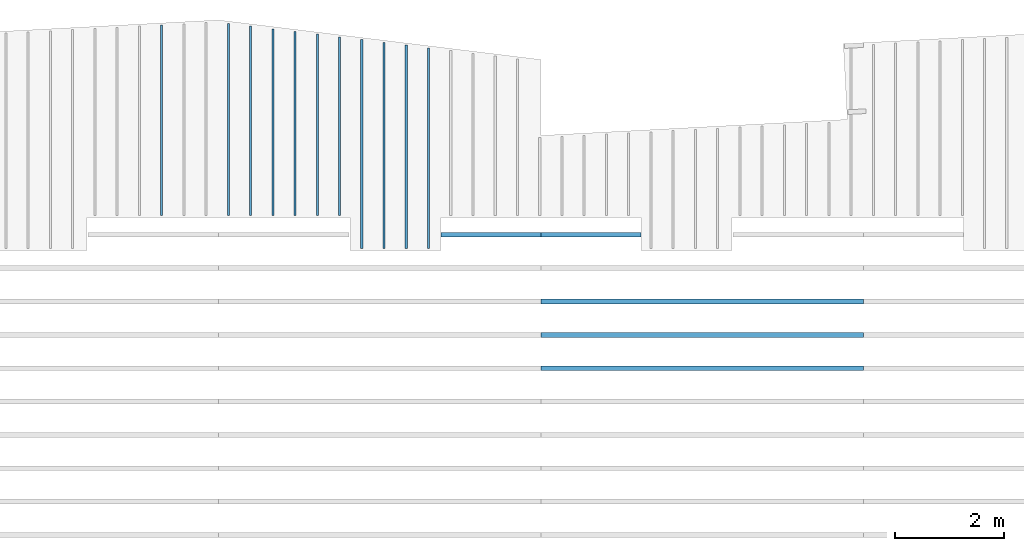
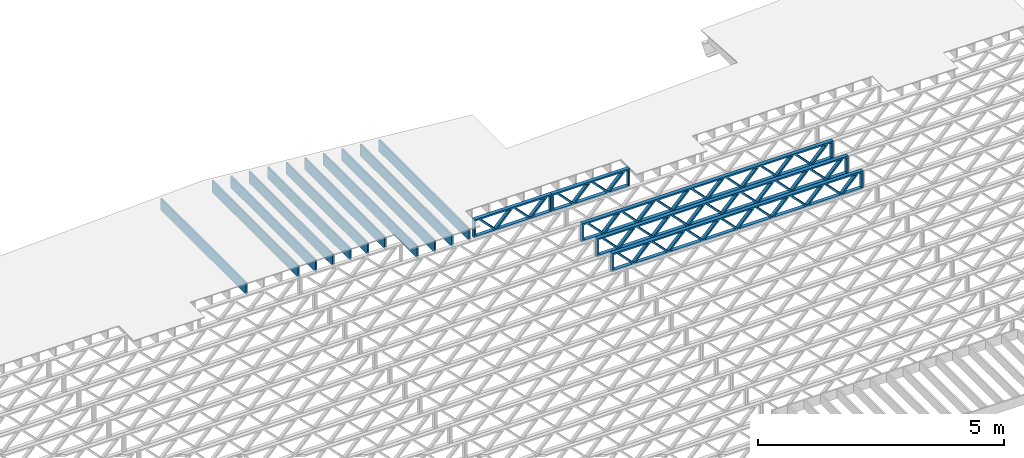
# One storey, part 9 of 13: 16 beams, 3 elements without a shape of their own.
"""IFC4 building model written with IfcOpenShell, lengths in feet."""

from ifc_helpers import new_model, entity, si_unit, converted_unit, derived_unit, direction, frame, frame_2d, origin, origin_2d_with_axis, place, context, subcontext, project, spatial, rectangle, extrude, source, transform, mapped, material, material_profile, profile_set, profile_usage, type_object, type_shapes, element, aggregate, save


model = new_model("IFC4")

# Units and contexts
model_context_1 = context("Model", 3, precision=0.0001, world=origin(), true_north=direction((6.12303176911189e-17, 1.0)))
model_context_2 = context("Model", 3, precision=0.0001, world=origin(), true_north=direction((6.12303176911189e-17, 1.0)))
body_context = subcontext(model_context_2, "Body", "Model", "MODEL_VIEW")
ifc_project = project(units=[converted_unit("LENGTHUNIT", "FOOT", entity("IfcRatioMeasure", 0.3048), si_unit("LENGTHUNIT", "METRE"), dimensions=[1, 0, 0, 0, 0, 0, 0]), converted_unit("AREAUNIT", "SQUARE FOOT", entity("IfcRatioMeasure", 0.09290304), si_unit("AREAUNIT", "SQUARE_METRE"), dimensions=[2, 0, 0, 0, 0, 0, 0]), converted_unit("VOLUMEUNIT", "CUBIC FOOT", entity("IfcRatioMeasure", 0.028316846592), si_unit("VOLUMEUNIT", "CUBIC_METRE"), dimensions=[3, 0, 0, 0, 0, 0, 0]), converted_unit("PLANEANGLEUNIT", "DEGREE", entity("IfcRatioMeasure", 0.0174532925199433), si_unit("PLANEANGLEUNIT", "RADIAN"), dimensions=[0, 0, 0, 0, 0, 0, 0]), si_unit("MASSUNIT", "GRAM", prefix="KILO"), derived_unit("MASSDENSITYUNIT", [(si_unit("MASSUNIT", "GRAM", prefix="KILO"), 1), (si_unit("LENGTHUNIT", "METRE"), -3)]), derived_unit("MOMENTOFINERTIAUNIT", [(si_unit("LENGTHUNIT", "METRE"), 4)]), si_unit("TIMEUNIT", "SECOND"), si_unit("FREQUENCYUNIT", "HERTZ"), si_unit("THERMODYNAMICTEMPERATUREUNIT", "DEGREE_CELSIUS"), derived_unit("THERMALTRANSMITTANCEUNIT", [(si_unit("MASSUNIT", "GRAM", prefix="KILO"), 1), (si_unit("THERMODYNAMICTEMPERATUREUNIT", "KELVIN"), -1), (si_unit("TIMEUNIT", "SECOND"), -3)]), derived_unit("VOLUMETRICFLOWRATEUNIT", [(si_unit("LENGTHUNIT", "METRE"), 3), (si_unit("TIMEUNIT", "SECOND"), -1)]), si_unit("ELECTRICCURRENTUNIT", "AMPERE"), si_unit("ELECTRICVOLTAGEUNIT", "VOLT"), si_unit("POWERUNIT", "WATT"), si_unit("FORCEUNIT", "NEWTON"), si_unit("ILLUMINANCEUNIT", "LUX"), si_unit("LUMINOUSFLUXUNIT", "LUMEN"), si_unit("LUMINOUSINTENSITYUNIT", "CANDELA"), derived_unit("USERDEFINED", [(si_unit("MASSUNIT", "GRAM", prefix="KILO"), -1), (si_unit("LENGTHUNIT", "METRE"), -2), (si_unit("TIMEUNIT", "SECOND"), 3), (si_unit("LUMINOUSFLUXUNIT", "LUMEN"), 1)]), derived_unit("LINEARVELOCITYUNIT", [(si_unit("LENGTHUNIT", "METRE"), 1), (si_unit("TIMEUNIT", "SECOND"), -1)]), si_unit("PRESSUREUNIT", "PASCAL"), derived_unit("USERDEFINED", [(si_unit("LENGTHUNIT", "METRE"), -2), (si_unit("MASSUNIT", "GRAM", prefix="KILO"), 1), (si_unit("TIMEUNIT", "SECOND"), -2)]), derived_unit("LINEARFORCEUNIT", [(si_unit("MASSUNIT", "GRAM", prefix="KILO"), 1), (si_unit("LENGTHUNIT", "METRE"), 1), (si_unit("TIMEUNIT", "SECOND"), -2), (si_unit("LENGTHUNIT", "METRE"), -1)]), derived_unit("PLANARFORCEUNIT", [(si_unit("MASSUNIT", "GRAM", prefix="KILO"), 1), (si_unit("LENGTHUNIT", "METRE"), 1), (si_unit("TIMEUNIT", "SECOND"), -2), (si_unit("LENGTHUNIT", "METRE"), -2)])], contexts=[model_context_1])

# Site, building, storey
site_placement = place(None, origin())
site = spatial("IfcSite", under=ifc_project, at=site_placement, CompositionType="ELEMENT")
building_placement = place(site_placement, origin())
building = spatial("IfcBuilding", under=site, at=building_placement, CompositionType="ELEMENT")
storey_placement = place(building_placement, frame((0.0, 0.0, 21.46875)))
storey = spatial("IfcBuildingStorey", under=building, at=storey_placement, Name="3RD FLOOR", CompositionType="ELEMENT", Elevation=21.46875)

# Assembly, beam
assembly_1_placement = place(storey_placement, origin())
assembly_1 = element("IfcElementAssembly", 1, at=assembly_1_placement, inside=storey, Name="Structural Beam System:Structural Framing System", ObjectType="Structural Beam System:Structural Framing System", AssemblyPlace="NOTDEFINED", PredefinedType="BEAM_GRID")
ifc_material_1 = material(Name="WOOD TRUSS", Category="Materials")
ifc_material_profile_1 = material_profile(ifc_material_1, rectangle(XDim=1.73473973950632, YDim=0.125, at=frame_2d((-1.11022302462516e-16, 8.32667268468867e-17), x_axis=(1.0, 0.0))))
ifc_material_profile_2 = material_profile(ifc_material_1, rectangle(XDim=1.73473973950633, YDim=0.125, at=frame_2d((-1.11022302462516e-16, 8.32667268468867e-17), x_axis=(1.0, 0.0))))
ifc_material_profile_3 = material_profile(ifc_material_1, rectangle(XDim=1.73473973950632, YDim=0.125, at=frame_2d((-5.55111512312578e-17, 1.38777878078145e-16), x_axis=(1.0, 0.0))))
ifc_material_profile_4 = material_profile(ifc_material_1, rectangle(XDim=1.73473973950633, YDim=0.125, at=frame_2d((-1.11022302462516e-16, 8.32667268468867e-17), x_axis=(1.0, 0.0))))
ifc_material_profile_5 = material_profile(ifc_material_1, rectangle(XDim=1.73473973950632, YDim=0.125, at=frame_2d((-1.11022302462516e-16, 8.32667268468867e-17), x_axis=(1.0, 0.0))))
ifc_material_profile_6 = material_profile(ifc_material_1, rectangle(XDim=1.73473973950633, YDim=0.125, at=frame_2d((-2.77555756156289e-16, 3.05311331771918e-16), x_axis=(1.0, 0.0))))
ifc_material_profile_7 = material_profile(ifc_material_1, rectangle(XDim=1.73473973950632, YDim=0.124999999999999, at=frame_2d((-3.88578058618805e-16, -2.4980018054066e-16), x_axis=(1.0, 0.0))))
ifc_material_profile_8 = material_profile(ifc_material_1, rectangle(XDim=1.73473973950633, YDim=0.125, at=frame_2d((2.77555756156289e-16, -3.05311331771918e-16), x_axis=(1.0, 0.0))))
ifc_material_profile_9 = material_profile(ifc_material_1, rectangle(XDim=1.73473973950632, YDim=0.124999999999999, at=frame_2d((-1.11022302462516e-16, 8.32667268468867e-17), x_axis=(1.0, 0.0))))
ifc_material_profile_10 = material_profile(ifc_material_1, rectangle(XDim=1.73473973950633, YDim=0.125, at=origin_2d_with_axis()))
ifc_material_profile_11 = material_profile(ifc_material_1, rectangle(XDim=0.124999999999982, YDim=0.291666666666668, at=origin_2d_with_axis()))
ifc_material_profile_12 = material_profile(ifc_material_1, rectangle(XDim=0.124999999999932, YDim=0.291666666666664, at=origin_2d_with_axis()))
ifc_material_profile_13 = material_profile(ifc_material_1, rectangle(XDim=1.25000000000002, YDim=0.29166666666667, at=origin_2d_with_axis()))
ifc_material_profile_14 = material_profile(ifc_material_1, rectangle(XDim=1.25000000000004, YDim=0.291666666666667, at=origin_2d_with_axis()))
ifc_profile_set_1 = profile_set([ifc_material_profile_1, ifc_material_profile_2, ifc_material_profile_3, ifc_material_profile_4, ifc_material_profile_5, ifc_material_profile_6, ifc_material_profile_7, ifc_material_profile_8, ifc_material_profile_9, ifc_material_profile_10, ifc_material_profile_11, ifc_material_profile_12, ifc_material_profile_13, ifc_material_profile_14])
ifc_profile_usage_1 = profile_usage(ifc_profile_set_1, cardinal=8)
beam_type_1 = type_object("IfcBeamType", PredefinedType="BEAM", material=ifc_profile_set_1)
shared_shape_1 = source(origin(), body_context, "Body", "SweptSolid", [
    extrude(rectangle(XDim=1.73473973950632, YDim=0.125, at=frame_2d((0.0, 1.66533453693773e-16), x_axis=(1.0, 0.0))), frame((1.95847610985504, -0.145833333333334, 0.0), z_axis=(0.0, 1.0, 0.0), x_axis=(0.693383046997606, 0.0, 0.720569184836762)), (0.0, 0.0, 1.0), 0.291666666666667),
    extrude(rectangle(XDim=1.73473973950633, YDim=0.125, at=frame_2d((-5.55111512312578e-17, 8.32667268468867e-17), x_axis=(1.0, 0.0))), frame((0.708190236181772, -0.145833333333334, 0.0), z_axis=(0.0, 1.0, 0.0), x_axis=(0.69338304699761, 0.0, -0.720569184836758)), (0.0, 0.0, 1.0), 0.291666666666667),
    extrude(rectangle(XDim=1.73473973950632, YDim=0.125, at=frame_2d((0.0, 1.66533453693773e-16), x_axis=(1.0, 0.0))), frame((-0.708190236181118, -0.145833333333334, 0.0), z_axis=(0.0, 1.0, 0.0), x_axis=(0.693383046997606, 0.0, 0.720569184836762)), (0.0, 0.0, 1.0), 0.291666666666667),
    extrude(rectangle(XDim=1.73473973950633, YDim=0.125, at=frame_2d((-2.22044604925031e-16, 2.22044604925031e-16), x_axis=(1.0, 0.0))), frame((-1.95847610985439, -0.145833333333334, 0.0), z_axis=(0.0, 1.0, 0.0), x_axis=(0.69338304699761, 0.0, -0.720569184836758)), (0.0, 0.0, 1.0), 0.291666666666666),
    extrude(rectangle(XDim=0.124999999999982, YDim=0.291666666666668, at=origin_2d_with_axis()), frame((-2.99999983968466, 0.0, 0.687500000000054), z_axis=(1.0, 0.0, 0.0), x_axis=(0.0, 0.0, -1.0)), (0.0, 0.0, 1.0), 5.99999967936932),
    extrude(rectangle(XDim=0.124999999999932, YDim=0.291666666666664, at=origin_2d_with_axis()), frame((-2.99999983968445, 0.0, -0.687499999999984), z_axis=(1.0, 0.0, 0.0), x_axis=(0.0, 0.0, -1.0)), (0.0, 0.0, 1.0), 5.99999967936911),
    extrude(rectangle(XDim=1.25000000000002, YDim=0.29166666666667, at=origin_2d_with_axis()), frame((2.87499983968464, 0.0, 0.0), z_axis=(1.0, 0.0, 0.0), x_axis=(0.0, 0.0, -1.0)), (0.0, 0.0, 1.0), 0.12500000000002),
    extrude(rectangle(XDim=1.25000000000004, YDim=0.291666666666667, at=origin_2d_with_axis()), frame((-2.99999983968466, 0.0, 0.0), z_axis=(1.0, 0.0, 0.0), x_axis=(0.0, 0.0, -1.0)), (0.0, 0.0, 1.0), 0.125000000000023),
])
type_shapes(beam_type_1, [shared_shape_1])
beam_1_placement = place(assembly_1_placement, frame((-186.738160325248, 957.861934882651, -0.947916666666874)))
beam_1 = element("IfcBeam", 2, at=beam_1_placement, type_object=beam_type_1, material=ifc_profile_usage_1, PredefinedType="BEAM", context=body_context, shape_type="MappedRepresentation", body=[
    mapped(shared_shape_1, transform((0.0, 0.0, 0.0), scale=1.0)),
])
aggregate(assembly_1, [beam_1])

# Assembly, beams
assembly_2_placement = place(storey_placement, origin())
assembly_2 = element("IfcElementAssembly", 3, at=assembly_2_placement, inside=storey, Name="Structural Beam System:Structural Framing System", ObjectType="Structural Beam System:Structural Framing System", AssemblyPlace="NOTDEFINED", PredefinedType="BEAM_GRID")
ifc_profile_usage_2 = profile_usage(ifc_profile_set_1, cardinal=8)
beam_type_2 = type_object("IfcBeamType", PredefinedType="BEAM", material=ifc_profile_set_1)
shared_shape_2 = source(origin(), body_context, "Body", "SweptSolid", [
    extrude(rectangle(XDim=1.73473973950632, YDim=0.124999999999999, at=frame_2d((5.55111512312578e-16, 7.21644966006352e-16), x_axis=(1.0, 0.0))), frame((5.95847627016997, -0.145833333333334, 0.0), z_axis=(0.0, 1.0, 0.0), x_axis=(0.693383046997606, 0.0, 0.720569184836762)), (0.0, 0.0, 1.0), 0.291666666666667),
    extrude(rectangle(XDim=1.73473973950633, YDim=0.125, at=origin_2d_with_axis()), frame((4.7081903964967, -0.145833333333334, 0.0), z_axis=(0.0, 1.0, 0.0), x_axis=(0.69338304699761, 0.0, -0.720569184836758)), (0.0, 0.0, 1.0), 0.291666666666666),
    extrude(rectangle(XDim=1.73473973950632, YDim=0.125, at=frame_2d((2.22044604925031e-16, 3.88578058618805e-16), x_axis=(1.0, 0.0))), frame((3.29180960350347, -0.145833333333334, 0.0), z_axis=(0.0, 1.0, 0.0), x_axis=(0.693383046997606, 0.0, 0.720569184836762)), (0.0, 0.0, 1.0), 0.291666666666667),
    extrude(rectangle(XDim=1.73473973950633, YDim=0.125, at=frame_2d((1.11022302462516e-16, -8.32667268468867e-17), x_axis=(1.0, 0.0))), frame((2.0415237298302, -0.145833333333334, 0.0), z_axis=(0.0, 1.0, 0.0), x_axis=(0.69338304699761, 0.0, -0.720569184836758)), (0.0, 0.0, 1.0), 0.291666666666667),
    extrude(rectangle(XDim=1.73473973950632, YDim=0.125, at=frame_2d((-5.55111512312578e-17, 1.38777878078145e-16), x_axis=(1.0, 0.0))), frame((0.625142936836964, -0.145833333333334, 0.0), z_axis=(0.0, 1.0, 0.0), x_axis=(0.693383046997606, 0.0, 0.720569184836762)), (0.0, 0.0, 1.0), 0.291666666666667),
    extrude(rectangle(XDim=1.73473973950633, YDim=0.125, at=frame_2d((-1.11022302462516e-16, 8.32667268468867e-17), x_axis=(1.0, 0.0))), frame((-0.625142936836306, -0.145833333333334, 0.0), z_axis=(0.0, 1.0, 0.0), x_axis=(0.69338304699761, 0.0, -0.720569184836758)), (0.0, 0.0, 1.0), 0.291666666666667),
    extrude(rectangle(XDim=1.73473973950632, YDim=0.125, at=frame_2d((-1.11022302462516e-16, 8.32667268468867e-17), x_axis=(1.0, 0.0))), frame((-2.04152372982954, -0.145833333333334, 0.0), z_axis=(0.0, 1.0, 0.0), x_axis=(0.693383046997606, 0.0, 0.720569184836762)), (0.0, 0.0, 1.0), 0.291666666666667),
    extrude(rectangle(XDim=1.73473973950633, YDim=0.125, at=origin_2d_with_axis()), frame((-3.29180960350281, -0.145833333333334, 0.0), z_axis=(0.0, 1.0, 0.0), x_axis=(0.69338304699761, 0.0, -0.720569184836758)), (0.0, 0.0, 1.0), 0.291666666666667),
    extrude(rectangle(XDim=1.73473973950632, YDim=0.124999999999999, at=frame_2d((-1.11022302462516e-16, 8.32667268468867e-17), x_axis=(1.0, 0.0))), frame((-4.70819039649604, -0.145833333333334, 0.0), z_axis=(0.0, 1.0, 0.0), x_axis=(0.693383046997606, 0.0, 0.720569184836762)), (0.0, 0.0, 1.0), 0.291666666666667),
    extrude(rectangle(XDim=1.73473973950633, YDim=0.125, at=frame_2d((-5.55111512312578e-16, 6.38378239159465e-16), x_axis=(1.0, 0.0))), frame((-5.95847627016931, -0.145833333333334, 0.0), z_axis=(0.0, 1.0, 0.0), x_axis=(0.69338304699761, 0.0, -0.720569184836758)), (0.0, 0.0, 1.0), 0.291666666666666),
    extrude(rectangle(XDim=1.73473973950632, YDim=0.125, at=frame_2d((-7.21644966006352e-16, -5.82867087928207e-16), x_axis=(1.0, 0.0))), frame((8.62514293683647, -0.145833333333334, 0.0), z_axis=(0.0, 1.0, 0.0), x_axis=(0.693383046997607, 0.0, 0.720569184836761)), (0.0, 0.0, 1.0), 0.291666666666667),
    extrude(rectangle(XDim=1.73473973950633, YDim=0.125, at=origin_2d_with_axis()), frame((7.3748570631632, -0.145833333333334, 0.0), z_axis=(0.0, 1.0, 0.0), x_axis=(0.69338304699761, 0.0, -0.720569184836758)), (0.0, 0.0, 1.0), 0.291666666666666),
    extrude(rectangle(XDim=1.73473973950632, YDim=0.124999999999999, at=frame_2d((-1.11022302462516e-16, 8.32667268468867e-17), x_axis=(1.0, 0.0))), frame((-7.37485706316255, -0.145833333333334, 0.0), z_axis=(0.0, 1.0, 0.0), x_axis=(0.693383046997606, 0.0, 0.720569184836762)), (0.0, 0.0, 1.0), 0.291666666666667),
    extrude(rectangle(XDim=1.73473973950633, YDim=0.125, at=origin_2d_with_axis()), frame((-8.62514293683582, -0.145833333333334, 0.0), z_axis=(0.0, 1.0, 0.0), x_axis=(0.69338304699761, 0.0, -0.720569184836758)), (0.0, 0.0, 1.0), 0.291666666666666),
    extrude(rectangle(XDim=0.124999999999982, YDim=0.291666666666668, at=origin_2d_with_axis()), frame((-9.66666666666609, 0.0, 0.687500000000054), z_axis=(1.0, 0.0, 0.0), x_axis=(0.0, 0.0, -1.0)), (0.0, 0.0, 1.0), 19.3333333333322),
    extrude(rectangle(XDim=0.124999999999932, YDim=0.291666666666664, at=origin_2d_with_axis()), frame((-9.66666666666588, 0.0, -0.687499999999984), z_axis=(1.0, 0.0, 0.0), x_axis=(0.0, 0.0, -1.0)), (0.0, 0.0, 1.0), 19.333333333332),
    extrude(rectangle(XDim=1.25000000000002, YDim=0.29166666666667, at=origin_2d_with_axis()), frame((9.54166666666607, 0.0, 0.0), z_axis=(1.0, 0.0, 0.0), x_axis=(0.0, 0.0, -1.0)), (0.0, 0.0, 1.0), 0.12500000000002),
    extrude(rectangle(XDim=1.25000000000004, YDim=0.291666666666667, at=origin_2d_with_axis()), frame((-9.66666666666609, 0.0, 0.0), z_axis=(1.0, 0.0, 0.0), x_axis=(0.0, 0.0, -1.0)), (0.0, 0.0, 1.0), 0.125000000000023),
])
type_shapes(beam_type_2, [shared_shape_2])
beam_2_placement = place(assembly_2_placement, frame((-174.071493818896, 953.861934882651, -0.947916666666661), z_axis=(0.0, 0.0, 1.0), x_axis=(-1.0, 0.0, 0.0)))
beam_2 = element("IfcBeam", 4, at=beam_2_placement, type_object=beam_type_2, material=ifc_profile_usage_2, PredefinedType="BEAM", context=body_context, shape_type="MappedRepresentation", body=[
    mapped(shared_shape_2, transform((0.0, 0.0, 0.0), scale=1.0)),
])
ifc_profile_usage_3 = profile_usage(ifc_profile_set_1, cardinal=8)
beam_3_placement = place(assembly_2_placement, frame((-174.071493818896, 951.861934882651, -0.947916666666661), z_axis=(0.0, 0.0, 1.0), x_axis=(-1.0, 0.0, 0.0)))
beam_3 = element("IfcBeam", 5, at=beam_3_placement, type_object=beam_type_2, material=ifc_profile_usage_3, PredefinedType="BEAM", context=body_context, shape_type="MappedRepresentation", body=[
    mapped(shared_shape_2, transform((0.0, 0.0, 0.0), scale=1.0)),
])
ifc_profile_usage_4 = profile_usage(ifc_profile_set_1, cardinal=8)
beam_4_placement = place(assembly_2_placement, frame((-174.071493818896, 949.861934882651, -0.947916666666661), z_axis=(0.0, 0.0, 1.0), x_axis=(-1.0, 0.0, 0.0)))
beam_4 = element("IfcBeam", 6, at=beam_4_placement, type_object=beam_type_2, material=ifc_profile_usage_4, PredefinedType="BEAM", context=body_context, shape_type="MappedRepresentation", body=[
    mapped(shared_shape_2, transform((0.0, 0.0, 0.0), scale=1.0)),
])

assembly_3_placement = place(storey_placement, origin())
assembly_3 = element("IfcElementAssembly", 7, at=assembly_3_placement, inside=storey, Name="Structural Beam System:Structural Framing System", ObjectType="Structural Beam System:Structural Framing System", AssemblyPlace="NOTDEFINED", PredefinedType="BEAM_GRID")
ifc_material_2 = material(Category="Materials")
ifc_material_profile_15 = material_profile(ifc_material_2, rectangle(XDim=0.9375, YDim=0.125000000000011, at=origin_2d_with_axis()))
ifc_profile_set_2 = profile_set([ifc_material_profile_15])
ifc_profile_usage_5 = profile_usage(ifc_profile_set_2, cardinal=8)
beam_type_3 = type_object("IfcBeamType", PredefinedType="BEAM", material=ifc_profile_set_2)
shared_shape_3 = source(origin(), body_context, "Body", "SweptSolid", [
    extrude(rectangle(XDim=0.9375, YDim=0.125000000000011, at=origin_2d_with_axis()), frame((-6.01743624187907, 0.0, 0.0), z_axis=(1.0, 0.0, 0.0), x_axis=(0.0, 0.0, -1.0)), (0.0, 0.0, 1.0), 12.0348724837581),
])
type_shapes(beam_type_3, [shared_shape_3])
beam_5_placement = place(assembly_3_placement, frame((-190.477622729298, 963.046034462908, -0.729166666666714), z_axis=(0.0, 0.0, 1.0), x_axis=(0.0, 1.0, 0.0)))
beam_5 = element("IfcBeam", 8, at=beam_5_placement, type_object=beam_type_3, material=ifc_profile_usage_5, PredefinedType="BEAM", context=body_context, shape_type="MappedRepresentation", body=[
    mapped(shared_shape_3, transform((0.0, 0.0, 0.0), scale=1.0)),
])
ifc_profile_usage_6 = profile_usage(ifc_profile_set_2, cardinal=8)
beam_type_4 = type_object("IfcBeamType", PredefinedType="BEAM", material=ifc_profile_set_2)
shared_shape_4 = source(origin(), body_context, "Body", "SweptSolid", [
    extrude(rectangle(XDim=0.9375, YDim=0.125000000000011, at=origin_2d_with_axis()), frame((-6.09929261581436, 0.0, 0.0), z_axis=(1.0, 0.0, 0.0), x_axis=(0.0, 0.0, -1.0)), (0.0, 0.0, 1.0), 12.1985852316287),
])
type_shapes(beam_type_4, [shared_shape_4])
beam_6_placement = place(assembly_3_placement, frame((-191.810956062631, 963.127890836844, -0.729166666666714), z_axis=(0.0, 0.0, 1.0), x_axis=(0.0, 1.0, 0.0)))
beam_6 = element("IfcBeam", 9, at=beam_6_placement, type_object=beam_type_4, material=ifc_profile_usage_6, PredefinedType="BEAM", context=body_context, shape_type="MappedRepresentation", body=[
    mapped(shared_shape_4, transform((0.0, 0.0, 0.0), scale=1.0)),
])
ifc_profile_usage_7 = profile_usage(ifc_profile_set_2, cardinal=8)
beam_type_5 = type_object("IfcBeamType", PredefinedType="BEAM", material=ifc_profile_set_2)
shared_shape_5 = source(origin(), body_context, "Body", "SweptSolid", [
    extrude(rectangle(XDim=0.9375, YDim=0.125000000000011, at=origin_2d_with_axis()), frame((-5.34486018441879, 0.0, 0.0), z_axis=(1.0, 0.0, 0.0), x_axis=(0.0, 0.0, -1.0)), (0.0, 0.0, 1.0), 10.6897203688376),
])
type_shapes(beam_type_5, [shared_shape_5])
beam_7_placement = place(assembly_3_placement, frame((-195.810956062631, 964.373461511808, -0.729166666666714), z_axis=(0.0, 0.0, 1.0), x_axis=(0.0, 1.0, 0.0)))
beam_7 = element("IfcBeam", 10, at=beam_7_placement, type_object=beam_type_5, material=ifc_profile_usage_7, PredefinedType="BEAM", context=body_context, shape_type="MappedRepresentation", body=[
    mapped(shared_shape_5, transform((0.0, 0.0, 0.0), scale=1.0)),
])
ifc_profile_usage_8 = profile_usage(ifc_profile_set_2, cardinal=8)
beam_type_6 = type_object("IfcBeamType", PredefinedType="BEAM", material=ifc_profile_set_2)
shared_shape_6 = source(origin(), body_context, "Body", "SweptSolid", [
    extrude(rectangle(XDim=0.9375, YDim=0.125000000000011, at=origin_2d_with_axis()), frame((-5.67228635016443, 0.0, 0.0), z_axis=(1.0, 0.0, 0.0), x_axis=(0.0, 0.0, -1.0)), (0.0, 0.0, 1.0), 11.3445727003289),
])
type_shapes(beam_type_6, [shared_shape_6])
beam_8_placement = place(assembly_3_placement, frame((-201.144289395965, 964.700886337237, -0.729166666666714), z_axis=(0.0, 0.0, 1.0), x_axis=(0.0, 1.0, 0.0)))
beam_8 = element("IfcBeam", 11, at=beam_8_placement, type_object=beam_type_6, material=ifc_profile_usage_8, PredefinedType="BEAM", context=body_context, shape_type="MappedRepresentation", body=[
    mapped(shared_shape_6, transform((0.0, 0.0, 0.0), scale=1.0)),
])
ifc_profile_usage_9 = profile_usage(ifc_profile_set_2, cardinal=8)
beam_type_7 = type_object("IfcBeamType", PredefinedType="BEAM", material=ifc_profile_set_2)
shared_shape_7 = source(origin(), body_context, "Body", "SweptSolid", [
    extrude(rectangle(XDim=0.9375, YDim=0.125000000000011, at=origin_2d_with_axis()), frame((-5.70174598058964, 0.0, 0.0), z_axis=(1.0, 0.0, 0.0), x_axis=(0.0, 0.0, -1.0)), (0.0, 0.0, 1.0), 11.4034919611793),
])
type_shapes(beam_type_7, [shared_shape_7])
beam_9_placement = place(assembly_3_placement, frame((-206.477622719368, 964.730344550269, -0.729166666666714), z_axis=(0.0, 0.0, 1.0), x_axis=(0.0, 1.0, 0.0)))
beam_9 = element("IfcBeam", 12, at=beam_9_placement, type_object=beam_type_7, material=ifc_profile_usage_9, PredefinedType="BEAM", context=body_context, shape_type="MappedRepresentation", body=[
    mapped(shared_shape_7, transform((0.0, 0.0, 0.0), scale=1.0)),
])
ifc_profile_usage_10 = profile_usage(ifc_profile_set_2, cardinal=8)
beam_type_8 = type_object("IfcBeamType", PredefinedType="BEAM", material=ifc_profile_set_2)
shared_shape_8 = source(origin(), body_context, "Body", "SweptSolid", [
    extrude(rectangle(XDim=0.9375, YDim=0.125000000000011, at=origin_2d_with_axis()), frame((-5.75414289160091, 0.0, 0.0), z_axis=(1.0, 0.0, 0.0), x_axis=(0.0, 0.0, -1.0)), (0.0, 0.0, 1.0), 11.5082857832018),
])
type_shapes(beam_type_8, [shared_shape_8])
beam_10_placement = place(assembly_3_placement, frame((-202.477622729298, 964.782742543594, -0.729166666666714), z_axis=(0.0, 0.0, 1.0), x_axis=(0.0, 1.0, 0.0)))
beam_10 = element("IfcBeam", 13, at=beam_10_placement, type_object=beam_type_8, material=ifc_profile_usage_10, PredefinedType="BEAM", context=body_context, shape_type="MappedRepresentation", body=[
    mapped(shared_shape_8, transform((0.0, 0.0, 0.0), scale=1.0)),
])
ifc_profile_usage_11 = profile_usage(ifc_profile_set_2, cardinal=8)
beam_type_9 = type_object("IfcBeamType", PredefinedType="BEAM", material=ifc_profile_set_2)
shared_shape_9 = source(origin(), body_context, "Body", "SweptSolid", [
    extrude(rectangle(XDim=0.9375, YDim=0.125000000000011, at=origin_2d_with_axis()), frame((-5.59042980872806, 0.0, 0.0), z_axis=(1.0, 0.0, 0.0), x_axis=(0.0, 0.0, -1.0)), (0.0, 0.0, 1.0), 11.1808596174561),
])
type_shapes(beam_type_9, [shared_shape_9])
beam_11_placement = place(assembly_3_placement, frame((-199.810956062631, 964.619030130879, -0.729166666666714), z_axis=(0.0, 0.0, 1.0), x_axis=(0.0, 1.0, 0.0)))
beam_11 = element("IfcBeam", 14, at=beam_11_placement, type_object=beam_type_9, material=ifc_profile_usage_11, PredefinedType="BEAM", context=body_context, shape_type="MappedRepresentation", body=[
    mapped(shared_shape_9, transform((0.0, 0.0, 0.0), scale=1.0)),
])
ifc_profile_usage_12 = profile_usage(ifc_profile_set_2, cardinal=8)
beam_type_10 = type_object("IfcBeamType", PredefinedType="BEAM", material=ifc_profile_set_2)
shared_shape_10 = source(origin(), body_context, "Body", "SweptSolid", [
    extrude(rectangle(XDim=0.9375, YDim=0.125000000000011, at=origin_2d_with_axis()), frame((-5.50857326729164, 0.0, 0.0), z_axis=(1.0, 0.0, 0.0), x_axis=(0.0, 0.0, -1.0)), (0.0, 0.0, 1.0), 11.0171465345833),
])
type_shapes(beam_type_10, [shared_shape_10])
beam_12_placement = place(assembly_3_placement, frame((-198.477622729298, 964.537173924522, -0.729166666666714), z_axis=(0.0, 0.0, 1.0), x_axis=(0.0, 1.0, 0.0)))
beam_12 = element("IfcBeam", 15, at=beam_12_placement, type_object=beam_type_10, material=ifc_profile_usage_12, PredefinedType="BEAM", context=body_context, shape_type="MappedRepresentation", body=[
    mapped(shared_shape_10, transform((0.0, 0.0, 0.0), scale=1.0)),
])
ifc_profile_usage_13 = profile_usage(ifc_profile_set_2, cardinal=8)
beam_type_11 = type_object("IfcBeamType", PredefinedType="BEAM", material=ifc_profile_set_2)
shared_shape_11 = source(origin(), body_context, "Body", "SweptSolid", [
    extrude(rectangle(XDim=0.9375, YDim=0.125000000000011, at=origin_2d_with_axis()), frame((-5.42671672585521, 0.0, 0.0), z_axis=(1.0, 0.0, 0.0), x_axis=(0.0, 0.0, -1.0)), (0.0, 0.0, 1.0), 10.8534334517104),
])
type_shapes(beam_type_11, [shared_shape_11])
beam_13_placement = place(assembly_3_placement, frame((-197.144289395965, 964.455317718165, -0.729166666666714), z_axis=(0.0, 0.0, 1.0), x_axis=(0.0, 1.0, 0.0)))
beam_13 = element("IfcBeam", 16, at=beam_13_placement, type_object=beam_type_11, material=ifc_profile_usage_13, PredefinedType="BEAM", context=body_context, shape_type="MappedRepresentation", body=[
    mapped(shared_shape_11, transform((0.0, 0.0, 0.0), scale=1.0)),
])
ifc_profile_usage_14 = profile_usage(ifc_profile_set_2, cardinal=8)
beam_type_12 = type_object("IfcBeamType", PredefinedType="BEAM", material=ifc_profile_set_2)
shared_shape_12 = source(origin(), body_context, "Body", "SweptSolid", [
    extrude(rectangle(XDim=0.9375, YDim=0.125000000000011, at=origin_2d_with_axis()), frame((-6.26300536368484, 0.0, 0.0), z_axis=(1.0, 0.0, 0.0), x_axis=(0.0, 0.0, -1.0)), (0.0, 0.0, 1.0), 12.5260107273697),
])
type_shapes(beam_type_12, [shared_shape_12])
beam_14_placement = place(assembly_3_placement, frame((-194.477622729298, 963.291603584714, -0.729166666666714), z_axis=(0.0, 0.0, 1.0), x_axis=(0.0, 1.0, 0.0)))
beam_14 = element("IfcBeam", 17, at=beam_14_placement, type_object=beam_type_12, material=ifc_profile_usage_14, PredefinedType="BEAM", context=body_context, shape_type="MappedRepresentation", body=[
    mapped(shared_shape_12, transform((0.0, 0.0, 0.0), scale=1.0)),
])
ifc_profile_usage_15 = profile_usage(ifc_profile_set_2, cardinal=8)
beam_type_13 = type_object("IfcBeamType", PredefinedType="BEAM", material=ifc_profile_set_2)
shared_shape_13 = source(origin(), body_context, "Body", "SweptSolid", [
    extrude(rectangle(XDim=0.9375, YDim=0.125000000000011, at=origin_2d_with_axis()), frame((-6.1811489897496, 0.0, 0.0), z_axis=(1.0, 0.0, 0.0), x_axis=(0.0, 0.0, -1.0)), (0.0, 0.0, 1.0), 12.3622979794992),
])
type_shapes(beam_type_13, [shared_shape_13])
beam_15_placement = place(assembly_3_placement, frame((-193.144289395965, 963.209747210779, -0.729166666666714), z_axis=(0.0, 0.0, 1.0), x_axis=(0.0, 1.0, 0.0)))
beam_15 = element("IfcBeam", 18, at=beam_15_placement, type_object=beam_type_13, material=ifc_profile_usage_15, PredefinedType="BEAM", context=body_context, shape_type="MappedRepresentation", body=[
    mapped(shared_shape_13, transform((0.0, 0.0, 0.0), scale=1.0)),
])
aggregate(assembly_3, [beam_5, beam_6, beam_7, beam_8, beam_9, beam_10, beam_11, beam_12, beam_13, beam_14, beam_15])

# Beam
ifc_profile_usage_16 = profile_usage(ifc_profile_set_1, cardinal=8)
beam_type_14 = type_object("IfcBeamType", PredefinedType="BEAM", material=ifc_profile_set_1)
shared_shape_14 = source(origin(), body_context, "Body", "SweptSolid", [
    extrude(rectangle(XDim=1.73473973950632, YDim=0.125, at=frame_2d((0.0, 1.66533453693773e-16), x_axis=(1.0, 0.0))), frame((1.95847612494153, -0.145833333333334, 0.0), z_axis=(0.0, 1.0, 0.0), x_axis=(0.693383046997606, 0.0, 0.720569184836762)), (0.0, 0.0, 1.0), 0.291666666666667),
    extrude(rectangle(XDim=1.73473973950633, YDim=0.125, at=frame_2d((-5.55111512312578e-17, 8.32667268468867e-17), x_axis=(1.0, 0.0))), frame((0.708190251268258, -0.145833333333334, 0.0), z_axis=(0.0, 1.0, 0.0), x_axis=(0.69338304699761, 0.0, -0.720569184836758)), (0.0, 0.0, 1.0), 0.291666666666667),
    extrude(rectangle(XDim=1.73473973950632, YDim=0.125, at=frame_2d((0.0, 1.66533453693773e-16), x_axis=(1.0, 0.0))), frame((-0.708190251267602, -0.145833333333334, 0.0), z_axis=(0.0, 1.0, 0.0), x_axis=(0.693383046997606, 0.0, 0.720569184836762)), (0.0, 0.0, 1.0), 0.291666666666667),
    extrude(rectangle(XDim=1.73473973950633, YDim=0.125, at=frame_2d((-2.22044604925031e-16, 2.22044604925031e-16), x_axis=(1.0, 0.0))), frame((-1.95847612494087, -0.145833333333334, 0.0), z_axis=(0.0, 1.0, 0.0), x_axis=(0.69338304699761, 0.0, -0.720569184836758)), (0.0, 0.0, 1.0), 0.291666666666666),
    extrude(rectangle(XDim=0.124999999999982, YDim=0.291666666666668, at=origin_2d_with_axis()), frame((-2.99999985477115, 0.0, 0.687500000000054), z_axis=(1.0, 0.0, 0.0), x_axis=(0.0, 0.0, -1.0)), (0.0, 0.0, 1.0), 5.99999970954229),
    extrude(rectangle(XDim=0.124999999999932, YDim=0.291666666666664, at=origin_2d_with_axis()), frame((-2.99999985477093, 0.0, -0.687499999999984), z_axis=(1.0, 0.0, 0.0), x_axis=(0.0, 0.0, -1.0)), (0.0, 0.0, 1.0), 5.99999970954208),
    extrude(rectangle(XDim=1.25000000000002, YDim=0.29166666666667, at=origin_2d_with_axis()), frame((2.87499985477113, 0.0, 0.0), z_axis=(1.0, 0.0, 0.0), x_axis=(0.0, 0.0, -1.0)), (0.0, 0.0, 1.0), 0.12500000000002),
    extrude(rectangle(XDim=1.25000000000004, YDim=0.291666666666667, at=origin_2d_with_axis()), frame((-2.99999985477115, 0.0, 0.0), z_axis=(1.0, 0.0, 0.0), x_axis=(0.0, 0.0, -1.0)), (0.0, 0.0, 1.0), 0.125000000000023),
])
type_shapes(beam_type_14, [shared_shape_14])
beam_16_placement = place(assembly_2_placement, frame((-180.738160630791, 957.861934882651, -0.947916666666654), z_axis=(0.0, 0.0, 1.0), x_axis=(-1.0, 0.0, 0.0)))
beam_16 = element("IfcBeam", 19, at=beam_16_placement, type_object=beam_type_14, material=ifc_profile_usage_16, PredefinedType="BEAM", context=body_context, shape_type="MappedRepresentation", body=[
    mapped(shared_shape_14, transform((0.0, 0.0, 0.0), scale=1.0)),
])

aggregate(assembly_2, [beam_2, beam_3, beam_4, beam_16])

save(model, "model.ifc")
